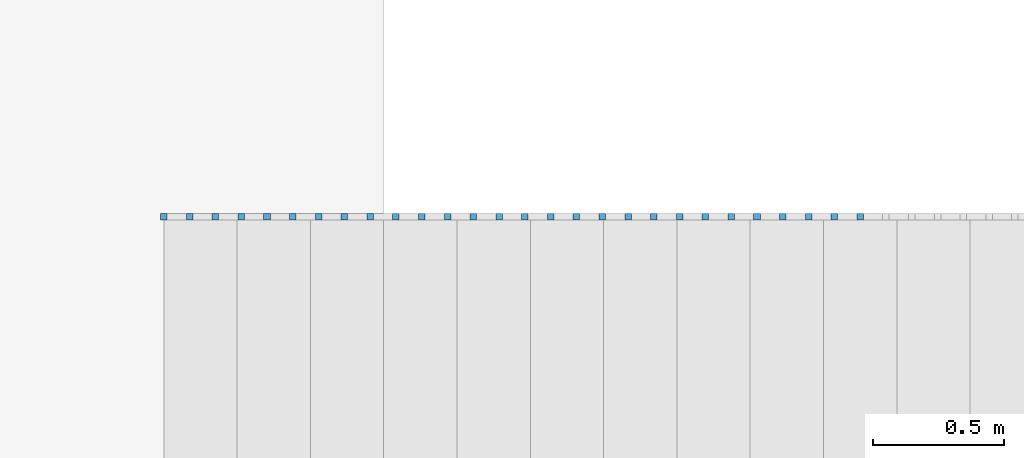
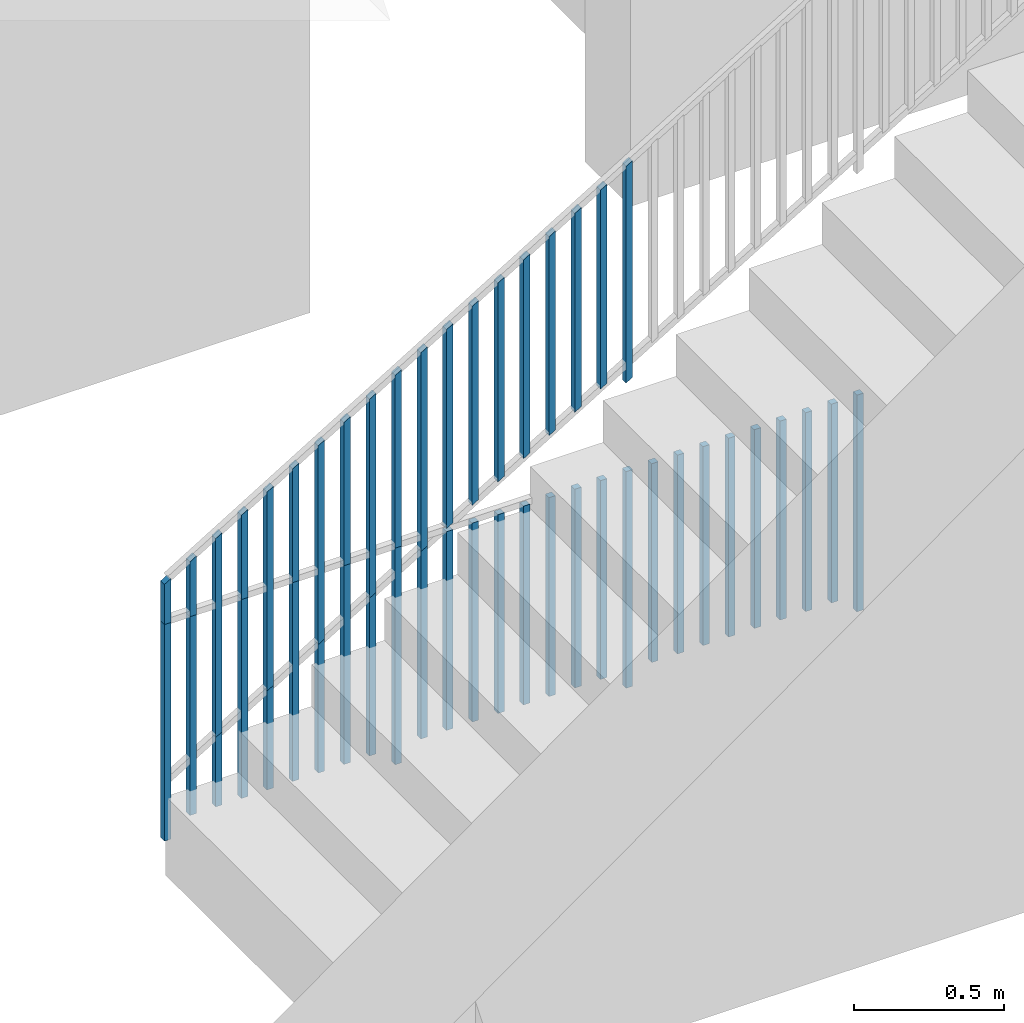
# One storey, part 20 of 23: 47 building element parts, 2 elements without a shape of their own.
"""IFC4 building model written with IfcOpenShell, lengths in metres."""

from ifc_helpers import new_model, entity, si_unit, converted_unit, derived_unit, direction, frame, origin_with_axes, place, context, subcontext, project, spatial, polygons, material, type_object, element, aggregate, save


model = new_model("IFC4")

# Units and contexts
model_context = context("Model", 3, precision=1e-05, world=origin_with_axes(), true_north=direction((0.0, 1.0)))
body_context = subcontext(model_context, "Body", "Model", "MODEL_VIEW")
ifc_project = project(units=[si_unit("LENGTHUNIT", "METRE"), si_unit("AREAUNIT", "SQUARE_METRE"), si_unit("VOLUMEUNIT", "CUBIC_METRE"), converted_unit("PLANEANGLEUNIT", "DEGREE", entity("IfcPlaneAngleMeasure", 0.0174532925199), si_unit("PLANEANGLEUNIT", "RADIAN"), dimensions=[0, 0, 0, 0, 0, 0, 0]), converted_unit("TIMEUNIT", "Year", entity("IfcTimeMeasure", 31556926.0), si_unit("TIMEUNIT", "SECOND"), dimensions=[0, 0, 1, 0, 0, 0, 0]), si_unit("MASSUNIT", "GRAM", prefix="KILO"), si_unit("THERMODYNAMICTEMPERATUREUNIT", "DEGREE_CELSIUS"), si_unit("LUMINOUSINTENSITYUNIT", "LUMEN"), si_unit("ENERGYUNIT", "JOULE", prefix="MEGA"), derived_unit("THERMALCONDUCTANCEUNIT", [(si_unit("POWERUNIT", "WATT"), 1), (si_unit("LENGTHUNIT", "METRE"), -1), (si_unit("THERMODYNAMICTEMPERATUREUNIT", "KELVIN"), -1)]), derived_unit("SPECIFICHEATCAPACITYUNIT", [(si_unit("ENERGYUNIT", "JOULE"), 1), (si_unit("MASSUNIT", "GRAM", prefix="KILO"), -1), (si_unit("THERMODYNAMICTEMPERATUREUNIT", "KELVIN"), -1)]), derived_unit("MASSDENSITYUNIT", [(si_unit("MASSUNIT", "GRAM", prefix="KILO"), 1), (si_unit("VOLUMEUNIT", "CUBIC_METRE"), -1)])], contexts=[model_context])

# Site, building, storey, space
site_placement = place(None, origin_with_axes())
site = spatial("IfcSite", under=ifc_project, at=site_placement, CompositionType="ELEMENT")
building_placement = place(site_placement, origin_with_axes())
building = spatial("IfcBuilding", under=site, at=building_placement, CompositionType="ELEMENT")
storey_placement = place(building_placement, origin_with_axes())
storey = spatial("IfcBuildingStorey", under=building, at=storey_placement, Name="0. Geschoss", CompositionType="ELEMENT", Elevation=0.0)
space_placement = place(storey_placement, frame((-11.4421993804, 1.37118776896, 0.0), z_axis=(0.0, 0.0, 1.0), x_axis=(0.0, -1.0, 0.0)))
space = spatial("IfcSpace", under=storey, at=space_placement, CompositionType="ELEMENT", PredefinedType="INTERNAL")

# Railing, building element parts
railing_type = type_object("IfcRailingType", PredefinedType="NOTDEFINED")
railing_1_placement = place(space_placement, frame((1.5, 8.0, 0.0), z_axis=(0.0, 0.0, 1.0), x_axis=(0.0, 1.0, 0.0)))
railing_1 = element("IfcRailing", 1, at=railing_1_placement, inside=space, type_object=railing_type, PredefinedType="NOTDEFINED")
ifc_material = material()
building_element_part_1_placement = place(railing_1_placement, origin_with_axes())
building_element_part_1 = element("IfcBuildingElementPart", 2, at=building_element_part_1_placement, material=ifc_material, PredefinedType="NOTDEFINED", context=body_context, shape_type="Tessellation", body=[
    polygons([(-0.8275, -0.9125, 0.0), (-0.8275, -0.8875, 0.0), (-0.8275, -0.8875, 0.88), (-0.8275, -0.9125, 0.88), (-0.8525, -0.9125, 0.0), (-0.8525, -0.8875, 0.0), (-0.8525, -0.8875, 0.88), (-0.8525, -0.9125, 0.88)], [[[1, 2, 3, 4]], [[1, 5, 6, 2]], [[2, 6, 7, 3]], [[4, 3, 7, 8]], [[5, 1, 4, 8]], [[6, 5, 8, 7]]], closed=True),
])
building_element_part_2_placement = place(railing_1_placement, origin_with_axes())
building_element_part_2 = element("IfcBuildingElementPart", 3, at=building_element_part_2_placement, material=ifc_material, PredefinedType="NOTDEFINED", context=body_context, shape_type="Tessellation", body=[
    polygons([(-0.728981481481, -0.9125, 0.07), (-0.728981481481, -0.8875, 0.07), (-0.728981481481, -0.8875, 0.8775), (-0.728981481481, -0.9125, 0.8775), (-0.753981481481, -0.9125, 0.07), (-0.753981481481, -0.8875, 0.07), (-0.753981481481, -0.8875, 0.8775), (-0.753981481481, -0.9125, 0.8775)], [[[1, 2, 3, 4]], [[1, 5, 6, 2]], [[2, 6, 7, 3]], [[4, 3, 7, 8]], [[5, 1, 4, 8]], [[6, 5, 8, 7]]], closed=True),
])
building_element_part_3_placement = place(railing_1_placement, origin_with_axes())
building_element_part_3 = element("IfcBuildingElementPart", 4, at=building_element_part_3_placement, material=ifc_material, PredefinedType="NOTDEFINED", context=body_context, shape_type="Tessellation", body=[
    polygons([(-0.630462962963, -0.9125, 0.07), (-0.630462962963, -0.8875, 0.07), (-0.630462962963, -0.8875, 0.8775), (-0.630462962963, -0.9125, 0.8775), (-0.655462962963, -0.9125, 0.07), (-0.655462962963, -0.8875, 0.07), (-0.655462962963, -0.8875, 0.8775), (-0.655462962963, -0.9125, 0.8775)], [[[1, 2, 3, 4]], [[1, 5, 6, 2]], [[2, 6, 7, 3]], [[4, 3, 7, 8]], [[5, 1, 4, 8]], [[6, 5, 8, 7]]], closed=True),
])
building_element_part_4_placement = place(railing_1_placement, origin_with_axes())
building_element_part_4 = element("IfcBuildingElementPart", 5, at=building_element_part_4_placement, material=ifc_material, PredefinedType="NOTDEFINED", context=body_context, shape_type="Tessellation", body=[
    polygons([(-0.531944444444, -0.9125, 0.07), (-0.531944444444, -0.8875, 0.07), (-0.531944444444, -0.8875, 0.8775), (-0.531944444444, -0.9125, 0.8775), (-0.556944444444, -0.9125, 0.07), (-0.556944444444, -0.8875, 0.07), (-0.556944444444, -0.8875, 0.8775), (-0.556944444444, -0.9125, 0.8775)], [[[1, 2, 3, 4]], [[1, 5, 6, 2]], [[2, 6, 7, 3]], [[4, 3, 7, 8]], [[5, 1, 4, 8]], [[6, 5, 8, 7]]], closed=True),
])
building_element_part_5_placement = place(railing_1_placement, origin_with_axes())
building_element_part_5 = element("IfcBuildingElementPart", 6, at=building_element_part_5_placement, material=ifc_material, PredefinedType="NOTDEFINED", context=body_context, shape_type="Tessellation", body=[
    polygons([(-0.433425925926, -0.9125, 0.07), (-0.433425925926, -0.8875, 0.07), (-0.433425925926, -0.8875, 0.8775), (-0.433425925926, -0.9125, 0.8775), (-0.458425925926, -0.9125, 0.07), (-0.458425925926, -0.8875, 0.07), (-0.458425925926, -0.8875, 0.8775), (-0.458425925926, -0.9125, 0.8775)], [[[1, 2, 3, 4]], [[1, 5, 6, 2]], [[2, 6, 7, 3]], [[4, 3, 7, 8]], [[5, 1, 4, 8]], [[6, 5, 8, 7]]], closed=True),
])
building_element_part_6_placement = place(railing_1_placement, origin_with_axes())
building_element_part_6 = element("IfcBuildingElementPart", 7, at=building_element_part_6_placement, material=ifc_material, PredefinedType="NOTDEFINED", context=body_context, shape_type="Tessellation", body=[
    polygons([(-0.334907407407, -0.9125, 0.07), (-0.334907407407, -0.8875, 0.07), (-0.334907407407, -0.8875, 0.8775), (-0.334907407407, -0.9125, 0.8775), (-0.359907407407, -0.9125, 0.07), (-0.359907407407, -0.8875, 0.07), (-0.359907407407, -0.8875, 0.8775), (-0.359907407407, -0.9125, 0.8775)], [[[1, 2, 3, 4]], [[1, 5, 6, 2]], [[2, 6, 7, 3]], [[4, 3, 7, 8]], [[5, 1, 4, 8]], [[6, 5, 8, 7]]], closed=True),
])
building_element_part_7_placement = place(railing_1_placement, origin_with_axes())
building_element_part_7 = element("IfcBuildingElementPart", 8, at=building_element_part_7_placement, material=ifc_material, PredefinedType="NOTDEFINED", context=body_context, shape_type="Tessellation", body=[
    polygons([(-0.236388888889, -0.9125, 0.07), (-0.236388888889, -0.8875, 0.07), (-0.236388888889, -0.8875, 0.8775), (-0.236388888889, -0.9125, 0.8775), (-0.261388888889, -0.9125, 0.07), (-0.261388888889, -0.8875, 0.07), (-0.261388888889, -0.8875, 0.8775), (-0.261388888889, -0.9125, 0.8775)], [[[1, 2, 3, 4]], [[1, 5, 6, 2]], [[2, 6, 7, 3]], [[4, 3, 7, 8]], [[5, 1, 4, 8]], [[6, 5, 8, 7]]], closed=True),
])
building_element_part_8_placement = place(railing_1_placement, origin_with_axes())
building_element_part_8 = element("IfcBuildingElementPart", 9, at=building_element_part_8_placement, material=ifc_material, PredefinedType="NOTDEFINED", context=body_context, shape_type="Tessellation", body=[
    polygons([(-0.13787037037, -0.9125, 0.07), (-0.13787037037, -0.8875, 0.07), (-0.13787037037, -0.8875, 0.8775), (-0.13787037037, -0.9125, 0.8775), (-0.16287037037, -0.9125, 0.07), (-0.16287037037, -0.8875, 0.07), (-0.16287037037, -0.8875, 0.8775), (-0.16287037037, -0.9125, 0.8775)], [[[1, 2, 3, 4]], [[1, 5, 6, 2]], [[2, 6, 7, 3]], [[4, 3, 7, 8]], [[5, 1, 4, 8]], [[6, 5, 8, 7]]], closed=True),
])
building_element_part_9_placement = place(railing_1_placement, origin_with_axes())
building_element_part_9 = element("IfcBuildingElementPart", 10, at=building_element_part_9_placement, material=ifc_material, PredefinedType="NOTDEFINED", context=body_context, shape_type="Tessellation", body=[
    polygons([(-0.0393518518519, -0.9125, 0.07), (-0.0393518518519, -0.8875, 0.07), (-0.0393518518519, -0.8875, 0.8775), (-0.0393518518519, -0.9125, 0.8775), (-0.0643518518519, -0.9125, 0.07), (-0.0643518518519, -0.8875, 0.07), (-0.0643518518519, -0.8875, 0.8775), (-0.0643518518519, -0.9125, 0.8775)], [[[1, 2, 3, 4]], [[1, 5, 6, 2]], [[2, 6, 7, 3]], [[4, 3, 7, 8]], [[5, 1, 4, 8]], [[6, 5, 8, 7]]], closed=True),
])
building_element_part_10_placement = place(railing_1_placement, origin_with_axes())
building_element_part_10 = element("IfcBuildingElementPart", 11, at=building_element_part_10_placement, material=ifc_material, PredefinedType="NOTDEFINED", context=body_context, shape_type="Tessellation", body=[
    polygons([(0.0591666666667, -0.9125, 0.0), (0.0591666666667, -0.8875, 0.0), (0.0591666666667, -0.8875, 0.88), (0.0591666666667, -0.9125, 0.88), (0.0341666666667, -0.9125, 0.0), (0.0341666666667, -0.8875, 0.0), (0.0341666666667, -0.8875, 0.88), (0.0341666666667, -0.9125, 0.88)], [[[1, 2, 3, 4]], [[1, 5, 6, 2]], [[2, 6, 7, 3]], [[4, 3, 7, 8]], [[5, 1, 4, 8]], [[6, 5, 8, 7]]], closed=True),
])
building_element_part_11_placement = place(railing_1_placement, origin_with_axes())
building_element_part_11 = element("IfcBuildingElementPart", 12, at=building_element_part_11_placement, material=ifc_material, PredefinedType="NOTDEFINED", context=body_context, shape_type="Tessellation", body=[
    polygons([(0.157685185185, -0.9125, 0.07), (0.157685185185, -0.8875, 0.07), (0.157685185185, -0.8875, 0.8775), (0.157685185185, -0.9125, 0.8775), (0.132685185185, -0.9125, 0.07), (0.132685185185, -0.8875, 0.07), (0.132685185185, -0.8875, 0.8775), (0.132685185185, -0.9125, 0.8775)], [[[1, 2, 3, 4]], [[1, 5, 6, 2]], [[2, 6, 7, 3]], [[4, 3, 7, 8]], [[5, 1, 4, 8]], [[6, 5, 8, 7]]], closed=True),
])
building_element_part_12_placement = place(railing_1_placement, origin_with_axes())
building_element_part_12 = element("IfcBuildingElementPart", 13, at=building_element_part_12_placement, material=ifc_material, PredefinedType="NOTDEFINED", context=body_context, shape_type="Tessellation", body=[
    polygons([(0.256203703704, -0.9125, 0.07), (0.256203703704, -0.8875, 0.07), (0.256203703704, -0.8875, 0.8775), (0.256203703704, -0.9125, 0.8775), (0.231203703704, -0.9125, 0.07), (0.231203703704, -0.8875, 0.07), (0.231203703704, -0.8875, 0.8775), (0.231203703704, -0.9125, 0.8775)], [[[1, 2, 3, 4]], [[1, 5, 6, 2]], [[2, 6, 7, 3]], [[4, 3, 7, 8]], [[5, 1, 4, 8]], [[6, 5, 8, 7]]], closed=True),
])
building_element_part_13_placement = place(railing_1_placement, origin_with_axes())
building_element_part_13 = element("IfcBuildingElementPart", 14, at=building_element_part_13_placement, material=ifc_material, PredefinedType="NOTDEFINED", context=body_context, shape_type="Tessellation", body=[
    polygons([(0.354722222222, -0.9125, 0.07), (0.354722222222, -0.8875, 0.07), (0.354722222222, -0.8875, 0.8775), (0.354722222222, -0.9125, 0.8775), (0.329722222222, -0.9125, 0.07), (0.329722222222, -0.8875, 0.07), (0.329722222222, -0.8875, 0.8775), (0.329722222222, -0.9125, 0.8775)], [[[1, 2, 3, 4]], [[1, 5, 6, 2]], [[2, 6, 7, 3]], [[4, 3, 7, 8]], [[5, 1, 4, 8]], [[6, 5, 8, 7]]], closed=True),
])
building_element_part_14_placement = place(railing_1_placement, origin_with_axes())
building_element_part_14 = element("IfcBuildingElementPart", 15, at=building_element_part_14_placement, material=ifc_material, PredefinedType="NOTDEFINED", context=body_context, shape_type="Tessellation", body=[
    polygons([(0.453240740741, -0.9125, 0.07), (0.453240740741, -0.8875, 0.07), (0.453240740741, -0.8875, 0.8775), (0.453240740741, -0.9125, 0.8775), (0.428240740741, -0.9125, 0.07), (0.428240740741, -0.8875, 0.07), (0.428240740741, -0.8875, 0.8775), (0.428240740741, -0.9125, 0.8775)], [[[1, 2, 3, 4]], [[1, 5, 6, 2]], [[2, 6, 7, 3]], [[4, 3, 7, 8]], [[5, 1, 4, 8]], [[6, 5, 8, 7]]], closed=True),
])
building_element_part_15_placement = place(railing_1_placement, origin_with_axes())
building_element_part_15 = element("IfcBuildingElementPart", 16, at=building_element_part_15_placement, material=ifc_material, PredefinedType="NOTDEFINED", context=body_context, shape_type="Tessellation", body=[
    polygons([(0.551759259259, -0.9125, 0.07), (0.551759259259, -0.8875, 0.07), (0.551759259259, -0.8875, 0.8775), (0.551759259259, -0.9125, 0.8775), (0.526759259259, -0.9125, 0.07), (0.526759259259, -0.8875, 0.07), (0.526759259259, -0.8875, 0.8775), (0.526759259259, -0.9125, 0.8775)], [[[1, 2, 3, 4]], [[1, 5, 6, 2]], [[2, 6, 7, 3]], [[4, 3, 7, 8]], [[5, 1, 4, 8]], [[6, 5, 8, 7]]], closed=True),
])
building_element_part_16_placement = place(railing_1_placement, origin_with_axes())
building_element_part_16 = element("IfcBuildingElementPart", 17, at=building_element_part_16_placement, material=ifc_material, PredefinedType="NOTDEFINED", context=body_context, shape_type="Tessellation", body=[
    polygons([(0.650277777778, -0.9125, 0.07), (0.650277777778, -0.8875, 0.07), (0.650277777778, -0.8875, 0.8775), (0.650277777778, -0.9125, 0.8775), (0.625277777778, -0.9125, 0.07), (0.625277777778, -0.8875, 0.07), (0.625277777778, -0.8875, 0.8775), (0.625277777778, -0.9125, 0.8775)], [[[1, 2, 3, 4]], [[1, 5, 6, 2]], [[2, 6, 7, 3]], [[4, 3, 7, 8]], [[5, 1, 4, 8]], [[6, 5, 8, 7]]], closed=True),
])
building_element_part_17_placement = place(railing_1_placement, origin_with_axes())
building_element_part_17 = element("IfcBuildingElementPart", 18, at=building_element_part_17_placement, material=ifc_material, PredefinedType="NOTDEFINED", context=body_context, shape_type="Tessellation", body=[
    polygons([(0.748796296296, -0.9125, 0.07), (0.748796296296, -0.8875, 0.07), (0.748796296296, -0.8875, 0.8775), (0.748796296296, -0.9125, 0.8775), (0.723796296296, -0.9125, 0.07), (0.723796296296, -0.8875, 0.07), (0.723796296296, -0.8875, 0.8775), (0.723796296296, -0.9125, 0.8775)], [[[1, 2, 3, 4]], [[1, 5, 6, 2]], [[2, 6, 7, 3]], [[4, 3, 7, 8]], [[5, 1, 4, 8]], [[6, 5, 8, 7]]], closed=True),
])
building_element_part_18_placement = place(railing_1_placement, origin_with_axes())
building_element_part_18 = element("IfcBuildingElementPart", 19, at=building_element_part_18_placement, material=ifc_material, PredefinedType="NOTDEFINED", context=body_context, shape_type="Tessellation", body=[
    polygons([(0.847314814815, -0.9125, 0.07), (0.847314814815, -0.8875, 0.07), (0.847314814815, -0.8875, 0.8775), (0.847314814815, -0.9125, 0.8775), (0.822314814815, -0.9125, 0.07), (0.822314814815, -0.8875, 0.07), (0.822314814815, -0.8875, 0.8775), (0.822314814815, -0.9125, 0.8775)], [[[1, 2, 3, 4]], [[1, 5, 6, 2]], [[2, 6, 7, 3]], [[4, 3, 7, 8]], [[5, 1, 4, 8]], [[6, 5, 8, 7]]], closed=True),
])
building_element_part_19_placement = place(railing_1_placement, origin_with_axes())
building_element_part_19 = element("IfcBuildingElementPart", 20, at=building_element_part_19_placement, material=ifc_material, PredefinedType="NOTDEFINED", context=body_context, shape_type="Tessellation", body=[
    polygons([(0.945833333333, -0.9125, 0.0), (0.945833333333, -0.8875, 0.0), (0.945833333333, -0.8875, 0.88), (0.945833333333, -0.9125, 0.88), (0.920833333333, -0.9125, 0.0), (0.920833333333, -0.8875, 0.0), (0.920833333333, -0.8875, 0.88), (0.920833333333, -0.9125, 0.88)], [[[1, 2, 3, 4]], [[1, 5, 6, 2]], [[2, 6, 7, 3]], [[4, 3, 7, 8]], [[5, 1, 4, 8]], [[6, 5, 8, 7]]], closed=True),
])
building_element_part_20_placement = place(railing_1_placement, origin_with_axes())
building_element_part_20 = element("IfcBuildingElementPart", 21, at=building_element_part_20_placement, material=ifc_material, PredefinedType="NOTDEFINED", context=body_context, shape_type="Tessellation", body=[
    polygons([(1.04435185185, -0.9125, 0.07), (1.04435185185, -0.8875, 0.07), (1.04435185185, -0.8875, 0.8775), (1.04435185185, -0.9125, 0.8775), (1.01935185185, -0.9125, 0.07), (1.01935185185, -0.8875, 0.07), (1.01935185185, -0.8875, 0.8775), (1.01935185185, -0.9125, 0.8775)], [[[1, 2, 3, 4]], [[1, 5, 6, 2]], [[2, 6, 7, 3]], [[4, 3, 7, 8]], [[5, 1, 4, 8]], [[6, 5, 8, 7]]], closed=True),
])
building_element_part_21_placement = place(railing_1_placement, origin_with_axes())
building_element_part_21 = element("IfcBuildingElementPart", 22, at=building_element_part_21_placement, material=ifc_material, PredefinedType="NOTDEFINED", context=body_context, shape_type="Tessellation", body=[
    polygons([(1.14287037037, -0.9125, 0.07), (1.14287037037, -0.8875, 0.07), (1.14287037037, -0.8875, 0.8775), (1.14287037037, -0.9125, 0.8775), (1.11787037037, -0.9125, 0.07), (1.11787037037, -0.8875, 0.07), (1.11787037037, -0.8875, 0.8775), (1.11787037037, -0.9125, 0.8775)], [[[1, 2, 3, 4]], [[1, 5, 6, 2]], [[2, 6, 7, 3]], [[4, 3, 7, 8]], [[5, 1, 4, 8]], [[6, 5, 8, 7]]], closed=True),
])
building_element_part_22_placement = place(railing_1_placement, origin_with_axes())
building_element_part_22 = element("IfcBuildingElementPart", 23, at=building_element_part_22_placement, material=ifc_material, PredefinedType="NOTDEFINED", context=body_context, shape_type="Tessellation", body=[
    polygons([(1.24138888889, -0.9125, 0.07), (1.24138888889, -0.8875, 0.07), (1.24138888889, -0.8875, 0.8775), (1.24138888889, -0.9125, 0.8775), (1.21638888889, -0.9125, 0.07), (1.21638888889, -0.8875, 0.07), (1.21638888889, -0.8875, 0.8775), (1.21638888889, -0.9125, 0.8775)], [[[1, 2, 3, 4]], [[1, 5, 6, 2]], [[2, 6, 7, 3]], [[4, 3, 7, 8]], [[5, 1, 4, 8]], [[6, 5, 8, 7]]], closed=True),
])
building_element_part_23_placement = place(railing_1_placement, origin_with_axes())
building_element_part_23 = element("IfcBuildingElementPart", 24, at=building_element_part_23_placement, material=ifc_material, PredefinedType="NOTDEFINED", context=body_context, shape_type="Tessellation", body=[
    polygons([(1.33990740741, -0.9125, 0.07), (1.33990740741, -0.8875, 0.07), (1.33990740741, -0.8875, 0.8775), (1.33990740741, -0.9125, 0.8775), (1.31490740741, -0.9125, 0.07), (1.31490740741, -0.8875, 0.07), (1.31490740741, -0.8875, 0.8775), (1.31490740741, -0.9125, 0.8775)], [[[1, 2, 3, 4]], [[1, 5, 6, 2]], [[2, 6, 7, 3]], [[4, 3, 7, 8]], [[5, 1, 4, 8]], [[6, 5, 8, 7]]], closed=True),
])
building_element_part_24_placement = place(railing_1_placement, origin_with_axes())
building_element_part_24 = element("IfcBuildingElementPart", 25, at=building_element_part_24_placement, material=ifc_material, PredefinedType="NOTDEFINED", context=body_context, shape_type="Tessellation", body=[
    polygons([(1.43842592593, -0.9125, 0.07), (1.43842592593, -0.8875, 0.07), (1.43842592593, -0.8875, 0.8775), (1.43842592593, -0.9125, 0.8775), (1.41342592593, -0.9125, 0.07), (1.41342592593, -0.8875, 0.07), (1.41342592593, -0.8875, 0.8775), (1.41342592593, -0.9125, 0.8775)], [[[1, 2, 3, 4]], [[1, 5, 6, 2]], [[2, 6, 7, 3]], [[4, 3, 7, 8]], [[5, 1, 4, 8]], [[6, 5, 8, 7]]], closed=True),
])
building_element_part_25_placement = place(railing_1_placement, origin_with_axes())
building_element_part_25 = element("IfcBuildingElementPart", 26, at=building_element_part_25_placement, material=ifc_material, PredefinedType="NOTDEFINED", context=body_context, shape_type="Tessellation", body=[
    polygons([(1.53694444444, -0.9125, 0.07), (1.53694444444, -0.8875, 0.07), (1.53694444444, -0.8875, 0.8775), (1.53694444444, -0.9125, 0.8775), (1.51194444444, -0.9125, 0.07), (1.51194444444, -0.8875, 0.07), (1.51194444444, -0.8875, 0.8775), (1.51194444444, -0.9125, 0.8775)], [[[1, 2, 3, 4]], [[1, 5, 6, 2]], [[2, 6, 7, 3]], [[4, 3, 7, 8]], [[5, 1, 4, 8]], [[6, 5, 8, 7]]], closed=True),
])
building_element_part_26_placement = place(railing_1_placement, origin_with_axes())
building_element_part_26 = element("IfcBuildingElementPart", 27, at=building_element_part_26_placement, material=ifc_material, PredefinedType="NOTDEFINED", context=body_context, shape_type="Tessellation", body=[
    polygons([(1.63546296296, -0.9125, 0.07), (1.63546296296, -0.8875, 0.07), (1.63546296296, -0.8875, 0.8775), (1.63546296296, -0.9125, 0.8775), (1.61046296296, -0.9125, 0.07), (1.61046296296, -0.8875, 0.07), (1.61046296296, -0.8875, 0.8775), (1.61046296296, -0.9125, 0.8775)], [[[1, 2, 3, 4]], [[1, 5, 6, 2]], [[2, 6, 7, 3]], [[4, 3, 7, 8]], [[5, 1, 4, 8]], [[6, 5, 8, 7]]], closed=True),
])
building_element_part_27_placement = place(railing_1_placement, origin_with_axes())
building_element_part_27 = element("IfcBuildingElementPart", 28, at=building_element_part_27_placement, material=ifc_material, PredefinedType="NOTDEFINED", context=body_context, shape_type="Tessellation", body=[
    polygons([(1.73398148148, -0.9125, 0.07), (1.73398148148, -0.8875, 0.07), (1.73398148148, -0.8875, 0.8775), (1.73398148148, -0.9125, 0.8775), (1.70898148148, -0.9125, 0.07), (1.70898148148, -0.8875, 0.07), (1.70898148148, -0.8875, 0.8775), (1.70898148148, -0.9125, 0.8775)], [[[1, 2, 3, 4]], [[1, 5, 6, 2]], [[2, 6, 7, 3]], [[4, 3, 7, 8]], [[5, 1, 4, 8]], [[6, 5, 8, 7]]], closed=True),
])
building_element_part_28_placement = place(railing_1_placement, origin_with_axes())
building_element_part_28 = element("IfcBuildingElementPart", 29, at=building_element_part_28_placement, material=ifc_material, PredefinedType="NOTDEFINED", context=body_context, shape_type="Tessellation", body=[
    polygons([(1.8325, -0.9125, 0.0), (1.8325, -0.8875, 0.0), (1.8325, -0.8875, 0.88), (1.8325, -0.9125, 0.88), (1.8075, -0.9125, 0.0), (1.8075, -0.8875, 0.0), (1.8075, -0.8875, 0.88), (1.8075, -0.9125, 0.88)], [[[1, 2, 3, 4]], [[1, 5, 6, 2]], [[2, 6, 7, 3]], [[4, 3, 7, 8]], [[5, 1, 4, 8]], [[6, 5, 8, 7]]], closed=True),
])
aggregate(railing_1, [building_element_part_1, building_element_part_2, building_element_part_3, building_element_part_4, building_element_part_5, building_element_part_6, building_element_part_7, building_element_part_8, building_element_part_9, building_element_part_10, building_element_part_11, building_element_part_12, building_element_part_13, building_element_part_14, building_element_part_15, building_element_part_16, building_element_part_17, building_element_part_18, building_element_part_19, building_element_part_20, building_element_part_21, building_element_part_22, building_element_part_23, building_element_part_24, building_element_part_25, building_element_part_26, building_element_part_27, building_element_part_28])

railing_2_placement = place(space_placement, frame((2.4, 7.16, 0.17), z_axis=(0.0, 0.0, 1.0), x_axis=(0.0, 1.0, 0.0)))
railing_2 = element("IfcRailing", 30, at=railing_2_placement, inside=space, type_object=railing_type, PredefinedType="NOTDEFINED")
building_element_part_29_placement = place(railing_2_placement, origin_with_axes())
building_element_part_29 = element("IfcBuildingElementPart", 31, at=building_element_part_29_placement, material=ifc_material, PredefinedType="NOTDEFINED", context=body_context, shape_type="Tessellation", body=[
    polygons([(0.0125, -0.0125, 0.00758928571429), (0.0125, 0.0125, 0.00758928571429), (0.0125, 0.0125, 0.887589285714), (0.0125, -0.0125, 0.887589285714), (-0.0125, -0.0125, -0.00758928571429), (-0.0125, 0.0125, -0.00758928571429), (-0.0125, 0.0125, 0.872410714286), (-0.0125, -0.0125, 0.872410714286)], [[[1, 2, 3, 4]], [[1, 5, 6, 2]], [[2, 6, 7, 3]], [[4, 3, 7, 8]], [[5, 1, 4, 8]], [[6, 5, 8, 7]]], closed=True),
])
building_element_part_30_placement = place(railing_2_placement, origin_with_axes())
building_element_part_30 = element("IfcBuildingElementPart", 32, at=building_element_part_30_placement, material=ifc_material, PredefinedType="NOTDEFINED", context=body_context, shape_type="Tessellation", body=[
    polygons([(0.111018518519, -0.0125, 0.137404100529), (0.111018518519, 0.0125, 0.137404100529), (0.111018518519, 0.0125, 0.944904100529), (0.111018518519, -0.0125, 0.944904100529), (0.0860185185185, -0.0125, 0.122225529101), (0.0860185185185, 0.0125, 0.122225529101), (0.0860185185185, 0.0125, 0.929725529101), (0.0860185185185, -0.0125, 0.929725529101)], [[[1, 2, 3, 4]], [[1, 5, 6, 2]], [[2, 6, 7, 3]], [[4, 3, 7, 8]], [[5, 1, 4, 8]], [[6, 5, 8, 7]]], closed=True),
])
building_element_part_31_placement = place(railing_2_placement, origin_with_axes())
building_element_part_31 = element("IfcBuildingElementPart", 33, at=building_element_part_31_placement, material=ifc_material, PredefinedType="NOTDEFINED", context=body_context, shape_type="Tessellation", body=[
    polygons([(0.209537037037, -0.0125, 0.197218915344), (0.209537037037, 0.0125, 0.197218915344), (0.209537037037, 0.0125, 1.00471891534), (0.209537037037, -0.0125, 1.00471891534), (0.184537037037, -0.0125, 0.182040343915), (0.184537037037, 0.0125, 0.182040343915), (0.184537037037, 0.0125, 0.989540343915), (0.184537037037, -0.0125, 0.989540343915)], [[[1, 2, 3, 4]], [[1, 5, 6, 2]], [[2, 6, 7, 3]], [[4, 3, 7, 8]], [[5, 1, 4, 8]], [[6, 5, 8, 7]]], closed=True),
])
building_element_part_32_placement = place(railing_2_placement, origin_with_axes())
building_element_part_32 = element("IfcBuildingElementPart", 34, at=building_element_part_32_placement, material=ifc_material, PredefinedType="NOTDEFINED", context=body_context, shape_type="Tessellation", body=[
    polygons([(0.308055555556, -0.0125, 0.257033730159), (0.308055555556, 0.0125, 0.257033730159), (0.308055555556, 0.0125, 1.06453373016), (0.308055555556, -0.0125, 1.06453373016), (0.283055555556, -0.0125, 0.24185515873), (0.283055555556, 0.0125, 0.24185515873), (0.283055555556, 0.0125, 1.04935515873), (0.283055555556, -0.0125, 1.04935515873)], [[[1, 2, 3, 4]], [[1, 5, 6, 2]], [[2, 6, 7, 3]], [[4, 3, 7, 8]], [[5, 1, 4, 8]], [[6, 5, 8, 7]]], closed=True),
])
building_element_part_33_placement = place(railing_2_placement, origin_with_axes())
building_element_part_33 = element("IfcBuildingElementPart", 35, at=building_element_part_33_placement, material=ifc_material, PredefinedType="NOTDEFINED", context=body_context, shape_type="Tessellation", body=[
    polygons([(0.406574074074, -0.0125, 0.316848544974), (0.406574074074, 0.0125, 0.316848544974), (0.406574074074, 0.0125, 1.12434854497), (0.406574074074, -0.0125, 1.12434854497), (0.381574074074, -0.0125, 0.301669973545), (0.381574074074, 0.0125, 0.301669973545), (0.381574074074, 0.0125, 1.10916997354), (0.381574074074, -0.0125, 1.10916997354)], [[[1, 2, 3, 4]], [[1, 5, 6, 2]], [[2, 6, 7, 3]], [[4, 3, 7, 8]], [[5, 1, 4, 8]], [[6, 5, 8, 7]]], closed=True),
])
building_element_part_34_placement = place(railing_2_placement, origin_with_axes())
building_element_part_34 = element("IfcBuildingElementPart", 36, at=building_element_part_34_placement, material=ifc_material, PredefinedType="NOTDEFINED", context=body_context, shape_type="Tessellation", body=[
    polygons([(0.505092592593, -0.0125, 0.376663359788), (0.505092592593, 0.0125, 0.376663359788), (0.505092592593, 0.0125, 1.18416335979), (0.505092592593, -0.0125, 1.18416335979), (0.480092592593, -0.0125, 0.36148478836), (0.480092592593, 0.0125, 0.36148478836), (0.480092592593, 0.0125, 1.16898478836), (0.480092592593, -0.0125, 1.16898478836)], [[[1, 2, 3, 4]], [[1, 5, 6, 2]], [[2, 6, 7, 3]], [[4, 3, 7, 8]], [[5, 1, 4, 8]], [[6, 5, 8, 7]]], closed=True),
])
building_element_part_35_placement = place(railing_2_placement, origin_with_axes())
building_element_part_35 = element("IfcBuildingElementPart", 37, at=building_element_part_35_placement, material=ifc_material, PredefinedType="NOTDEFINED", context=body_context, shape_type="Tessellation", body=[
    polygons([(0.603611111111, -0.0125, 0.436478174603), (0.603611111111, 0.0125, 0.436478174603), (0.603611111111, 0.0125, 1.2439781746), (0.603611111111, -0.0125, 1.2439781746), (0.578611111111, -0.0125, 0.421299603175), (0.578611111111, 0.0125, 0.421299603175), (0.578611111111, 0.0125, 1.22879960317), (0.578611111111, -0.0125, 1.22879960317)], [[[1, 2, 3, 4]], [[1, 5, 6, 2]], [[2, 6, 7, 3]], [[4, 3, 7, 8]], [[5, 1, 4, 8]], [[6, 5, 8, 7]]], closed=True),
])
building_element_part_36_placement = place(railing_2_placement, origin_with_axes())
building_element_part_36 = element("IfcBuildingElementPart", 38, at=building_element_part_36_placement, material=ifc_material, PredefinedType="NOTDEFINED", context=body_context, shape_type="Tessellation", body=[
    polygons([(0.70212962963, -0.0125, 0.496292989418), (0.70212962963, 0.0125, 0.496292989418), (0.70212962963, 0.0125, 1.30379298942), (0.70212962963, -0.0125, 1.30379298942), (0.67712962963, -0.0125, 0.481114417989), (0.67712962963, 0.0125, 0.481114417989), (0.67712962963, 0.0125, 1.28861441799), (0.67712962963, -0.0125, 1.28861441799)], [[[1, 2, 3, 4]], [[1, 5, 6, 2]], [[2, 6, 7, 3]], [[4, 3, 7, 8]], [[5, 1, 4, 8]], [[6, 5, 8, 7]]], closed=True),
])
building_element_part_37_placement = place(railing_2_placement, origin_with_axes())
building_element_part_37 = element("IfcBuildingElementPart", 39, at=building_element_part_37_placement, material=ifc_material, PredefinedType="NOTDEFINED", context=body_context, shape_type="Tessellation", body=[
    polygons([(0.800648148148, -0.0125, 0.556107804233), (0.800648148148, 0.0125, 0.556107804233), (0.800648148148, 0.0125, 1.36360780423), (0.800648148148, -0.0125, 1.36360780423), (0.775648148148, -0.0125, 0.540929232804), (0.775648148148, 0.0125, 0.540929232804), (0.775648148148, 0.0125, 1.3484292328), (0.775648148148, -0.0125, 1.3484292328)], [[[1, 2, 3, 4]], [[1, 5, 6, 2]], [[2, 6, 7, 3]], [[4, 3, 7, 8]], [[5, 1, 4, 8]], [[6, 5, 8, 7]]], closed=True),
])
building_element_part_38_placement = place(railing_2_placement, origin_with_axes())
building_element_part_38 = element("IfcBuildingElementPart", 40, at=building_element_part_38_placement, material=ifc_material, PredefinedType="NOTDEFINED", context=body_context, shape_type="Tessellation", body=[
    polygons([(0.899166666667, -0.0125, 0.545922619048), (0.899166666667, 0.0125, 0.545922619048), (0.899166666667, 0.0125, 1.42592261905), (0.899166666667, -0.0125, 1.42592261905), (0.874166666667, -0.0125, 0.530744047619), (0.874166666667, 0.0125, 0.530744047619), (0.874166666667, 0.0125, 1.41074404762), (0.874166666667, -0.0125, 1.41074404762)], [[[1, 2, 3, 4]], [[1, 5, 6, 2]], [[2, 6, 7, 3]], [[4, 3, 7, 8]], [[5, 1, 4, 8]], [[6, 5, 8, 7]]], closed=True),
])
building_element_part_39_placement = place(railing_2_placement, origin_with_axes())
building_element_part_39 = element("IfcBuildingElementPart", 41, at=building_element_part_39_placement, material=ifc_material, PredefinedType="NOTDEFINED", context=body_context, shape_type="Tessellation", body=[
    polygons([(0.997685185185, -0.0125, 0.675737433862), (0.997685185185, 0.0125, 0.675737433862), (0.997685185185, 0.0125, 1.48323743386), (0.997685185185, -0.0125, 1.48323743386), (0.972685185185, -0.0125, 0.660558862434), (0.972685185185, 0.0125, 0.660558862434), (0.972685185185, 0.0125, 1.46805886243), (0.972685185185, -0.0125, 1.46805886243)], [[[1, 2, 3, 4]], [[1, 5, 6, 2]], [[2, 6, 7, 3]], [[4, 3, 7, 8]], [[5, 1, 4, 8]], [[6, 5, 8, 7]]], closed=True),
])
building_element_part_40_placement = place(railing_2_placement, origin_with_axes())
building_element_part_40 = element("IfcBuildingElementPart", 42, at=building_element_part_40_placement, material=ifc_material, PredefinedType="NOTDEFINED", context=body_context, shape_type="Tessellation", body=[
    polygons([(1.0962037037, -0.0125, 0.735552248677), (1.0962037037, 0.0125, 0.735552248677), (1.0962037037, 0.0125, 1.54305224868), (1.0962037037, -0.0125, 1.54305224868), (1.0712037037, -0.0125, 0.720373677249), (1.0712037037, 0.0125, 0.720373677249), (1.0712037037, 0.0125, 1.52787367725), (1.0712037037, -0.0125, 1.52787367725)], [[[1, 2, 3, 4]], [[1, 5, 6, 2]], [[2, 6, 7, 3]], [[4, 3, 7, 8]], [[5, 1, 4, 8]], [[6, 5, 8, 7]]], closed=True),
])
building_element_part_41_placement = place(railing_2_placement, origin_with_axes())
building_element_part_41 = element("IfcBuildingElementPart", 43, at=building_element_part_41_placement, material=ifc_material, PredefinedType="NOTDEFINED", context=body_context, shape_type="Tessellation", body=[
    polygons([(1.19472222222, -0.0125, 0.795367063492), (1.19472222222, 0.0125, 0.795367063492), (1.19472222222, 0.0125, 1.60286706349), (1.19472222222, -0.0125, 1.60286706349), (1.16972222222, -0.0125, 0.780188492063), (1.16972222222, 0.0125, 0.780188492063), (1.16972222222, 0.0125, 1.58768849206), (1.16972222222, -0.0125, 1.58768849206)], [[[1, 2, 3, 4]], [[1, 5, 6, 2]], [[2, 6, 7, 3]], [[4, 3, 7, 8]], [[5, 1, 4, 8]], [[6, 5, 8, 7]]], closed=True),
])
building_element_part_42_placement = place(railing_2_placement, origin_with_axes())
building_element_part_42 = element("IfcBuildingElementPart", 44, at=building_element_part_42_placement, material=ifc_material, PredefinedType="NOTDEFINED", context=body_context, shape_type="Tessellation", body=[
    polygons([(1.29324074074, -0.0125, 0.855181878307), (1.29324074074, 0.0125, 0.855181878307), (1.29324074074, 0.0125, 1.66268187831), (1.29324074074, -0.0125, 1.66268187831), (1.26824074074, -0.0125, 0.840003306878), (1.26824074074, 0.0125, 0.840003306878), (1.26824074074, 0.0125, 1.64750330688), (1.26824074074, -0.0125, 1.64750330688)], [[[1, 2, 3, 4]], [[1, 5, 6, 2]], [[2, 6, 7, 3]], [[4, 3, 7, 8]], [[5, 1, 4, 8]], [[6, 5, 8, 7]]], closed=True),
])
building_element_part_43_placement = place(railing_2_placement, origin_with_axes())
building_element_part_43 = element("IfcBuildingElementPart", 45, at=building_element_part_43_placement, material=ifc_material, PredefinedType="NOTDEFINED", context=body_context, shape_type="Tessellation", body=[
    polygons([(1.39175925926, -0.0125, 0.914996693122), (1.39175925926, 0.0125, 0.914996693122), (1.39175925926, 0.0125, 1.72249669312), (1.39175925926, -0.0125, 1.72249669312), (1.36675925926, -0.0125, 0.899818121693), (1.36675925926, 0.0125, 0.899818121693), (1.36675925926, 0.0125, 1.70731812169), (1.36675925926, -0.0125, 1.70731812169)], [[[1, 2, 3, 4]], [[1, 5, 6, 2]], [[2, 6, 7, 3]], [[4, 3, 7, 8]], [[5, 1, 4, 8]], [[6, 5, 8, 7]]], closed=True),
])
building_element_part_44_placement = place(railing_2_placement, origin_with_axes())
building_element_part_44 = element("IfcBuildingElementPart", 46, at=building_element_part_44_placement, material=ifc_material, PredefinedType="NOTDEFINED", context=body_context, shape_type="Tessellation", body=[
    polygons([(1.49027777778, -0.0125, 0.974811507937), (1.49027777778, 0.0125, 0.974811507937), (1.49027777778, 0.0125, 1.78231150794), (1.49027777778, -0.0125, 1.78231150794), (1.46527777778, -0.0125, 0.959632936508), (1.46527777778, 0.0125, 0.959632936508), (1.46527777778, 0.0125, 1.76713293651), (1.46527777778, -0.0125, 1.76713293651)], [[[1, 2, 3, 4]], [[1, 5, 6, 2]], [[2, 6, 7, 3]], [[4, 3, 7, 8]], [[5, 1, 4, 8]], [[6, 5, 8, 7]]], closed=True),
])
building_element_part_45_placement = place(railing_2_placement, origin_with_axes())
building_element_part_45 = element("IfcBuildingElementPart", 47, at=building_element_part_45_placement, material=ifc_material, PredefinedType="NOTDEFINED", context=body_context, shape_type="Tessellation", body=[
    polygons([(1.5887962963, -0.0125, 1.03462632275), (1.5887962963, 0.0125, 1.03462632275), (1.5887962963, 0.0125, 1.84212632275), (1.5887962963, -0.0125, 1.84212632275), (1.5637962963, -0.0125, 1.01944775132), (1.5637962963, 0.0125, 1.01944775132), (1.5637962963, 0.0125, 1.82694775132), (1.5637962963, -0.0125, 1.82694775132)], [[[1, 2, 3, 4]], [[1, 5, 6, 2]], [[2, 6, 7, 3]], [[4, 3, 7, 8]], [[5, 1, 4, 8]], [[6, 5, 8, 7]]], closed=True),
])
building_element_part_46_placement = place(railing_2_placement, origin_with_axes())
building_element_part_46 = element("IfcBuildingElementPart", 48, at=building_element_part_46_placement, material=ifc_material, PredefinedType="NOTDEFINED", context=body_context, shape_type="Tessellation", body=[
    polygons([(1.68731481481, -0.0125, 1.09444113757), (1.68731481481, 0.0125, 1.09444113757), (1.68731481481, 0.0125, 1.90194113757), (1.68731481481, -0.0125, 1.90194113757), (1.66231481481, -0.0125, 1.07926256614), (1.66231481481, 0.0125, 1.07926256614), (1.66231481481, 0.0125, 1.88676256614), (1.66231481481, -0.0125, 1.88676256614)], [[[1, 2, 3, 4]], [[1, 5, 6, 2]], [[2, 6, 7, 3]], [[4, 3, 7, 8]], [[5, 1, 4, 8]], [[6, 5, 8, 7]]], closed=True),
])
building_element_part_47_placement = place(railing_2_placement, origin_with_axes())
building_element_part_47 = element("IfcBuildingElementPart", 49, at=building_element_part_47_placement, material=ifc_material, PredefinedType="NOTDEFINED", context=body_context, shape_type="Tessellation", body=[
    polygons([(1.78583333333, -0.0125, 1.08425595238), (1.78583333333, 0.0125, 1.08425595238), (1.78583333333, 0.0125, 1.96425595238), (1.78583333333, -0.0125, 1.96425595238), (1.76083333333, -0.0125, 1.06907738095), (1.76083333333, 0.0125, 1.06907738095), (1.76083333333, 0.0125, 1.94907738095), (1.76083333333, -0.0125, 1.94907738095)], [[[1, 2, 3, 4]], [[1, 5, 6, 2]], [[2, 6, 7, 3]], [[4, 3, 7, 8]], [[5, 1, 4, 8]], [[6, 5, 8, 7]]], closed=True),
])
aggregate(railing_2, [building_element_part_29, building_element_part_30, building_element_part_31, building_element_part_32, building_element_part_33, building_element_part_34, building_element_part_35, building_element_part_36, building_element_part_37, building_element_part_38, building_element_part_39, building_element_part_40, building_element_part_41, building_element_part_42, building_element_part_43, building_element_part_44, building_element_part_45, building_element_part_46, building_element_part_47])

save(model, "model.ifc")
